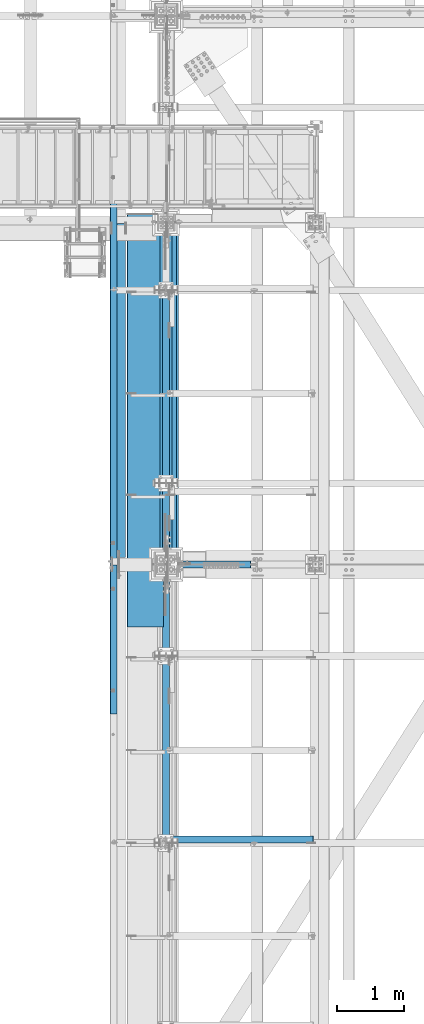
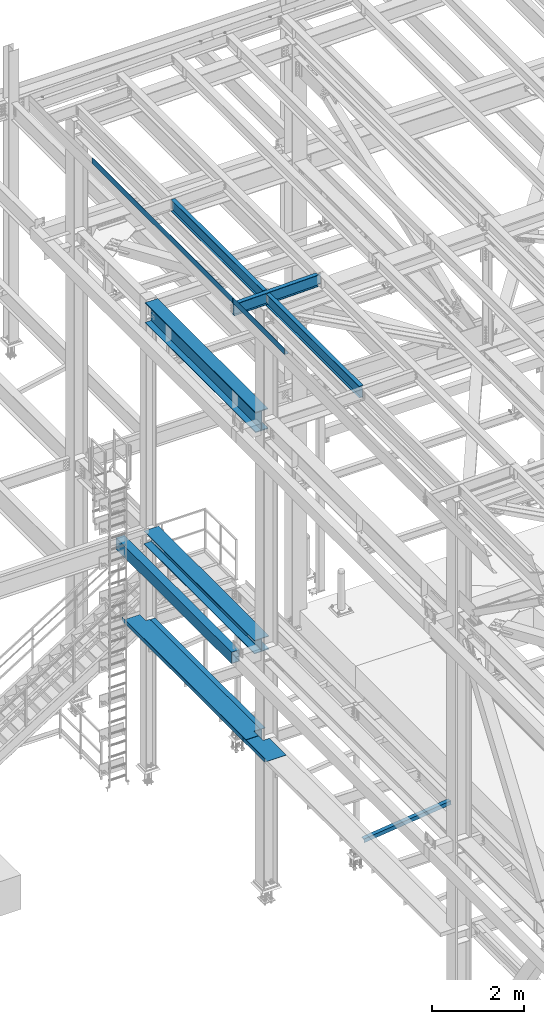
# One storey, part 1877 of 3843: 12 beams, 11 elements without a shape of their own.
"""IFC2X3 building model written with IfcOpenShell, lengths in millimetres."""

from ifc_helpers import new_model, si_unit, frame, origin_with_axes, place, context, subcontext, project, spatial, faceted_brep, material, type_object, element, aggregate, save


model = new_model("IFC2X3")

# Units and contexts
model_context = context("Model", 3, precision=1e-05, world=origin_with_axes())
body_context = subcontext(model_context, "Body", "Model", "MODEL_VIEW")
ifc_project = project(units=[si_unit("LENGTHUNIT", "METRE", prefix="MILLI"), si_unit("AREAUNIT", "SQUARE_METRE"), si_unit("VOLUMEUNIT", "CUBIC_METRE"), si_unit("MASSUNIT", "GRAM", prefix="KILO"), si_unit("TIMEUNIT", "SECOND"), si_unit("PLANEANGLEUNIT", "RADIAN"), si_unit("SOLIDANGLEUNIT", "STERADIAN"), si_unit("THERMODYNAMICTEMPERATUREUNIT", "DEGREE_CELSIUS"), si_unit("LUMINOUSINTENSITYUNIT", "LUMEN")], contexts=[model_context])

# Site, building, storey
site_placement = place(None, origin_with_axes())
site = spatial("IfcSite", under=ifc_project, at=site_placement, CompositionType="ELEMENT")
building_placement = place(site_placement, origin_with_axes())
building = spatial("IfcBuilding", under=site, at=building_placement, Name="Undefined", CompositionType="ELEMENT")
storey_placement = place(building_placement, origin_with_axes())
storey = spatial("IfcBuildingStorey", under=building, at=storey_placement, Name="Undefined", CompositionType="ELEMENT", Elevation=0.0)

# Assembly, beam
assembly_1_placement = place(storey_placement, origin_with_axes())
assembly_1 = element("IfcElementAssembly", 1, at=assembly_1_placement, inside=storey, Name="ANGLE", AssemblyPlace="NOTDEFINED", PredefinedType="RIGID_FRAME")
ifc_material_1 = material(Name="STEEL/A572-50")
beam_type_1 = type_object("IfcBeamType", Name="L4X4X3/8", PredefinedType="NOTDEFINED")
beam_1_placement = place(assembly_1_placement, frame((38788.5093206542, 79860.675782, 33960.1419503901), z_axis=(0.0, 1.0, 0.0), x_axis=(-0.993268693078032, 0.0, -0.115833084009098)))
beam_1 = element("IfcBeam", 2, at=beam_1_placement, type_object=beam_type_1, material=ifc_material_1, Name="ANGLE", ObjectType="L4X4X3/8", context=body_context, shape_type="Brep", body=[
    faceted_brep([(0.0, 50.8000000000029, -50.8000000000029), (0.0, 50.8000000000029, 50.8000000000029), (2192.8104802954, 50.7999999940694, 50.8000000000029), (2192.8104802954, 50.7999999940694, -50.8000000000029), (0.0, 41.2750000000015, 50.8000000000029), (2192.81048029537, 41.2749999940788, 50.8000000000029), (0.0, 41.2749999999942, -41.2750000000015), (2192.81048029537, 41.2749999940788, -41.2750000000015), (0.0, -50.8000000000029, -41.2750000000015), (2192.81048029512, -50.8000000058528, -41.2750000000015), (0.0, -50.8000000000029, -50.8000000000029), (2192.81048029512, -50.8000000058528, -50.8000000000029)], [[[0, 1, 2, 3]], [[1, 4, 5, 2]], [[4, 6, 7, 5]], [[6, 8, 9, 7]], [[8, 10, 11, 9]], [[10, 0, 3, 11]], [[5, 7, 9, 11, 3, 2]], [[10, 8, 6, 4, 1, 0]]]),
])
aggregate(assembly_1, [beam_1])

assembly_2_placement = place(storey_placement, origin_with_axes())
assembly_2 = element("IfcElementAssembly", 3, at=assembly_2_placement, inside=storey, Name="BEAM", AssemblyPlace="NOTDEFINED", PredefinedType="RIGID_FRAME")
ifc_material_2 = material(Name="STEEL/A36")
beam_type_2 = type_object("IfcBeamType", PredefinedType="NOTDEFINED")
beam_2_placement = place(assembly_2_placement, frame((35839.3101110435, 82861.15, 45717.1843160686), z_axis=(0.0, -1.0, 0.0), x_axis=(-0.999776270257024, 0.0, -0.0211520550054595)))
beam_2 = element("IfcBeam", 4, at=beam_2_placement, type_object=beam_type_2, material=ifc_material_2, Name="BENT_PLATE", context=body_context, shape_type="Brep", body=[
    faceted_brep([(95.2499999992069, -161.924999997405, 1117.60000004772), (98.4252606008595, -161.924999997434, 1120.77499999999), (98.4252606000809, -0.000137225979415234, 1120.77499999999), (95.2499999984138, -3.17499999993015, 1117.60000004771), (0.0, -0.000137226030346937, 1120.77499999999), (-7.27595761418343e-12, -3.17500000000291, 1117.60000004771), (-7.27595761418343e-12, -3.17500000000291, -1120.775), (95.2499999984138, -3.17499999993015, -1120.775), (-7.27595761418343e-12, 3.17499999998836, 1120.775), (-7.27595761418343e-12, 3.17499999998836, -1120.775), (101.599999998383, 3.17500000006112, 1120.775), (101.599999998383, 3.17500000006112, -1120.775), (101.599999999198, -161.924999997369, 1120.775), (101.599999999198, -161.924999997369, -1120.775), (95.2499999992069, -161.924999997405, -1120.775)], [[[0, 1, 2, 3]], [[3, 2, 4, 5]], [[6, 7, 3, 5]], [[8, 9, 6, 5, 4]], [[9, 8, 10, 11]], [[11, 10, 12, 13]], [[1, 12, 10, 8, 4, 2]], [[7, 14, 0, 3]], [[7, 6, 9, 11, 13, 14]], [[14, 13, 12, 1, 0]]]),
])
aggregate(assembly_2, [beam_2])

assembly_3_placement = place(storey_placement, origin_with_axes())
assembly_3 = element("IfcElementAssembly", 5, at=assembly_3_placement, inside=storey, Name="BEAM", AssemblyPlace="NOTDEFINED", PredefinedType="RIGID_FRAME")
beam_3_placement = place(assembly_3_placement, frame((35839.3101110586, 87048.975, 45717.1843160679), z_axis=(0.0, -1.0, 0.0), x_axis=(-0.999776270257024, 0.0, -0.0211520550054595)))
beam_3 = element("IfcBeam", 6, at=beam_3_placement, type_object=beam_type_2, material=ifc_material_2, Name="BENT_PLATE", context=body_context, shape_type="Brep", body=[
    faceted_brep([(-3.50355549016967e-07, -3.17499999742722, -3048.00000001723), (3.50421032635495e-07, -3.17500000260043, 3048.00000001724), (3.5035191103816e-07, 3.17499999739084, 3048.00000001724), (-3.50424670614302e-07, 3.17500000256405, -3048.00000001723), (101.599999864371, 3.17499999856227, 3048.00000000522), (101.599998739839, 3.17500000373548, -3048.00000002925), (95.249998765099, -3.17499999632128, -3048.00000002851), (95.2499998896274, -3.17500000149448, 3048.00000000597), (101.600000309205, -161.925000875126, 3047.9999999938), (101.599999608374, -161.925000446165, -3048.00000004067), (95.2500003092064, -161.925000900388, 3047.99999999456), (95.2499996083752, -161.925000471427, -3048.00000003992)], [[[0, 1, 2, 3]], [[3, 2, 4, 5]], [[1, 0, 6, 7]], [[5, 4, 8, 9]], [[4, 2, 1, 7, 10, 8]], [[7, 6, 11, 10]], [[6, 0, 3, 5, 9, 11]], [[10, 11, 9, 8]]]),
])
aggregate(assembly_3, [beam_3])

assembly_4_placement = place(storey_placement, origin_with_axes())
assembly_4 = element("IfcElementAssembly", 7, at=assembly_4_placement, inside=storey, Name="BEAM", AssemblyPlace="NOTDEFINED", PredefinedType="RIGID_FRAME")
ifc_material_3 = material(Name="STEEL/A992")
beam_type_3 = type_object("IfcBeamType", Name="W21X101", PredefinedType="NOTDEFINED")
beam_4_placement = place(assembly_4_placement, frame((36576.0, 83985.1, 42197.3375), z_axis=(0.0, 0.0, 1.0), x_axis=(0.0, 1.0, 0.0)))
beam_4 = element("IfcBeam", 8, at=beam_4_placement, type_object=beam_type_3, material=ifc_material_3, Name="BEAM", ObjectType="W21X101", context=body_context, shape_type="Brep", body=[
    faceted_brep([(198.4375, -155.574999999997, -271.462500000001), (198.4375, 155.574999999997, -271.462500000001), (4989.51250000004, 155.574999999997, -271.462500000001), (4989.51250000004, -155.574999999997, -271.462500000001), (198.4375, -155.574999999997, -250.824999999997), (198.4375, -6.34999999999854, -250.824999999997), (198.4375, -6.34999999999854, 250.824999999997), (198.4375, -155.574999999997, 250.824999999997), (198.4375, -155.574999999997, 271.462500000001), (198.4375, 155.574999999997, 271.462500000001), (198.4375, 155.574999999997, 250.824999999997), (198.4375, 6.34999999999854, 250.824999999997), (198.4375, 6.34999999999854, -250.824999999997), (198.4375, 155.574999999997, -250.824999999997), (4989.51250000004, -155.574999999997, -250.824999999997), (4989.51250000004, -6.34999999999854, -250.824999999997), (4989.51250000004, -6.34999999999854, 250.824999999997), (4989.51250000004, -155.574999999997, 250.824999999997), (4989.51250000004, -155.574999999997, 271.462500000001), (4989.51250000004, 155.574999999997, 271.462500000001), (4989.51250000004, 155.574999999997, 250.824999999997), (4989.51250000004, 6.34999999999854, 250.824999999997), (4989.51250000004, 6.34999999999854, -250.824999999997), (4989.51250000004, 155.574999999997, -250.824999999997)], [[[0, 1, 2, 3]], [[0, 4, 5, 6, 7, 8, 9, 10, 11, 12, 13, 1]], [[5, 4, 14, 15]], [[6, 5, 15, 16]], [[7, 6, 16, 17]], [[8, 7, 17, 18]], [[9, 8, 18, 19]], [[10, 9, 19, 20]], [[11, 10, 20, 21]], [[12, 11, 21, 22]], [[13, 12, 22, 23]], [[1, 13, 23, 2]], [[22, 21, 20, 19, 18, 17, 16, 15, 14, 3, 2, 23]], [[4, 0, 3, 14]]]),
])
aggregate(assembly_4, [beam_4])

assembly_5_placement = place(storey_placement, origin_with_axes())
assembly_5 = element("IfcElementAssembly", 9, at=assembly_5_placement, inside=storey, Name="GIRT", AssemblyPlace="NOTDEFINED", PredefinedType="RIGID_FRAME")
ifc_material_4 = material()
beam_type_4 = type_object("IfcBeamType", Name="HSS12X8X3/8", PredefinedType="NOTDEFINED")
beam_5_placement = place(assembly_5_placement, frame((35861.625, 83985.1, 36252.15), z_axis=(0.0, 0.0, 1.0), x_axis=(0.0, 1.0, 0.0)))
beam_5 = element("IfcBeam", 10, at=beam_5_placement, type_object=beam_type_4, material=ifc_material_4, Name="GIRT", ObjectType="HSS12X8X3/8", context=body_context, shape_type="Brep", body=[
    faceted_brep([(5113.33750000001, -101.599999999999, 152.400000000001), (5113.33750000001, 101.599999999999, 152.400000000001), (103.1875, 101.600000000006, 152.400000000001), (103.1875, -101.600000000006, 152.400000000001), (5113.33750000001, -101.599999999999, -152.400000000001), (103.1875, -101.600000000006, -152.400000000001), (5113.33750000001, 101.599999999999, -152.400000000001), (103.1875, 101.600000000006, -152.400000000001), (5113.33750000001, -92.0749999999971, 142.875), (5113.33750000001, 92.0749999999971, 142.875), (5113.33750000001, 92.0749999999971, -142.875), (5113.33750000001, -92.0749999999971, -142.875), (103.1875, -92.0749999999971, 142.875), (103.1875, 92.0749999999971, 142.875), (103.1875, 92.0749999999971, -142.875), (103.1875, -92.0749999999971, -142.875)], [[[0, 1, 2, 3]], [[4, 0, 3, 5]], [[6, 4, 5, 7]], [[1, 6, 7, 2]], [[0, 4, 6, 1], [8, 9, 10, 11]], [[9, 8, 12, 13]], [[10, 9, 13, 14]], [[11, 10, 14, 15]], [[8, 11, 15, 12]], [[7, 5, 3, 2], [14, 13, 12, 15]]]),
])
aggregate(assembly_5, [beam_5])

assembly_6_placement = place(storey_placement, origin_with_axes())
assembly_6 = element("IfcElementAssembly", 11, at=assembly_6_placement, inside=storey, Name="BEAM", AssemblyPlace="NOTDEFINED", PredefinedType="RIGID_FRAME")
beam_type_5 = type_object("IfcBeamType", Name="W12X19", PredefinedType="NOTDEFINED")
beam_6_placement = place(assembly_6_placement, frame((36575.9999999997, 83985.1, 45575.6071293694), z_axis=(0.0, 0.0, 1.0), x_axis=(0.0, 1.0, 0.0)))
beam_6 = element("IfcBeam", 12, at=beam_6_placement, type_object=beam_type_5, material=ifc_material_3, Name="BEAM", ObjectType="W12X19", context=body_context, shape_type="Brep", body=[
    faceted_brep([(15.8750000000146, -3.17500000000291, -128.587499998961), (15.8750000000146, 3.17500000000291, -128.587499998961), (53.9750001907523, 3.17500000000291, -128.587499998961), (53.9750001907523, -3.17500000000291, -128.587499998961), (58.8350797087915, 3.17500000000291, -129.554229921552), (58.8350797087915, -3.17500000000291, -129.554229921552), (62.9552561769524, 3.17500000000291, -132.307243822026), (62.9552561769524, -3.17500000000291, -132.307243822026), (65.7082700774336, 3.17500000000291, -136.42742029018), (65.7082700774336, -3.17500000000291, -136.42742029018), (66.6750000000175, -3.17500000000291, -141.287499808226), (66.6750000000175, 3.17500000000291, -141.287499808226), (66.6750000000175, 3.17500000000291, -144.462500000001), (66.6750000000175, 50.8000000000029, -144.462500000001), (66.6750000000175, 50.8000000000029, -153.987500000003), (66.6750000000175, -50.8000000000029, -153.987500000003), (66.6750000000175, -50.8000000000029, -144.462500000001), (66.6750000000175, -3.17500000000291, -144.462500000001), (4048.125, 50.8000000000029, 144.462500000001), (4048.125, 3.17500000000291, 144.462500000001), (66.6750000000175, 3.17500000000291, 144.462500000001), (66.6750000000175, 50.8000000000029, 144.462500000001), (53.9750001907523, -3.17500000000291, 128.587500001042), (53.9750001907523, 3.17500000000291, 128.587500001042), (15.8750000000146, 3.17500000000291, 128.587500001042), (15.8750000000146, -3.17500000000291, 128.587500001042), (58.8350797087915, -3.17500000000291, 129.554229923633), (58.8350797087915, 3.17500000000291, 129.554229923633), (62.9552561769524, -3.17500000000291, 132.307243824107), (62.9552561769524, 3.17500000000291, 132.307243824107), (65.7082700774336, -3.17500000000291, 136.427420292261), (65.7082700774336, 3.17500000000291, 136.427420292261), (66.6750000000175, -3.17500000000291, 141.287499810307), (66.6750000000175, 3.17500000000291, 141.287499810307), (4048.125, -50.8000000000029, 153.987500000003), (4048.125, 50.8000000000029, 153.987500000003), (66.6750000000175, 50.8000000000029, 153.987500000003), (66.6750000000175, -50.8000000000029, 153.987500000003), (4048.125, -50.8000000000029, 144.462500000001), (66.6750000000175, -50.8000000000029, 144.462500000001), (4048.125, -3.17500000000291, 144.462500000001), (66.6750000000175, -3.17500000000291, 144.462500000001), (4048.125, -3.17500000000291, 141.2874998103), (4048.125, 3.17500000000291, 141.2874998103), (4049.09172992258, -3.17500000000291, 136.427420292253), (4049.09172992258, 3.17500000000291, 136.427420292253), (4051.84474382307, -3.17500000000291, 132.3072438241), (4051.84474382307, 3.17500000000291, 132.3072438241), (4055.96492029123, -3.17500000000291, 129.554229923626), (4055.96492029123, 3.17500000000291, 129.554229923626), (4060.82499980927, -3.17500000000291, 128.587500001035), (4060.82499980927, 3.17500000000291, 128.587500001035), (4098.925, -3.17500000000291, 128.587500001035), (4098.925, 3.17500000000291, 128.587500001035), (4098.925, 3.17500000000291, -114.712499998452), (4098.925, 3.17500000000291, 115.887500001547), (4098.925, -3.17500000000291, -128.587499998968), (4098.925, 3.17500000000291, -128.587499998968), (4060.82499980927, -3.17500000000291, -128.587499998968), (4060.82499980927, 3.17500000000291, -128.587499998968), (4055.96492029123, -3.17500000000291, -129.554229921559), (4055.96492029123, 3.17500000000291, -129.554229921559), (4051.84474382307, -3.17500000000291, -132.307243822033), (4051.84474382307, 3.17500000000291, -132.307243822033), (4049.09172992258, -3.17500000000291, -136.427420290187), (4049.09172992258, 3.17500000000291, -136.427420290187), (4048.125, -3.17500000000291, -141.287499808233), (4048.125, 3.17500000000291, -141.287499808233), (4048.125, -3.17500000000291, -144.462500000001), (4048.125, -50.8000000000029, -144.462500000001), (4048.125, -50.8000000000029, -153.987500000003), (4048.125, 50.8000000000029, -153.987500000003), (4048.125, 50.8000000000029, -144.462500000001), (4048.125, 3.17500000000291, -144.462500000001), (15.8750000000146, 3.17500000000291, -114.712499998386), (15.8750000000146, 3.17500000000291, 115.887500001612)], [[[0, 1, 2, 3]], [[3, 2, 4, 5]], [[5, 4, 6, 7]], [[7, 6, 8, 9]], [[10, 11, 12, 13, 14, 15, 16, 17]], [[9, 8, 11, 10]], [[18, 19, 20, 21]], [[22, 23, 24, 25]], [[26, 27, 23, 22]], [[28, 29, 27, 26]], [[30, 31, 29, 28]], [[32, 33, 31, 30]], [[34, 35, 36, 37]], [[38, 34, 37, 39]], [[40, 38, 39, 41]], [[37, 36, 21, 20, 33, 32, 41, 39]], [[35, 18, 21, 36]], [[34, 38, 40, 42, 43, 19, 18, 35]], [[44, 45, 43, 42]], [[46, 47, 45, 44]], [[48, 49, 47, 46]], [[50, 51, 49, 48]], [[52, 53, 51, 50]], [[54, 55, 53, 52, 56, 57]], [[56, 58, 59, 57]], [[60, 61, 59, 58]], [[62, 63, 61, 60]], [[64, 65, 63, 62]], [[66, 67, 65, 64]], [[68, 69, 70, 71, 72, 73, 67, 66]], [[69, 68, 17, 16]], [[70, 69, 16, 15]], [[71, 70, 15, 14]], [[72, 71, 14, 13]], [[73, 72, 13, 12]], [[6, 4, 2, 1, 74, 75, 24, 23, 27, 29, 31, 33, 20, 19, 43, 45, 47, 49, 51, 53, 55, 54, 57, 59, 61, 63, 65, 67, 73, 12, 11, 8]], [[25, 24, 75, 74, 1, 0]], [[68, 66, 64, 62, 60, 58, 56, 52, 50, 48, 46, 44, 42, 40, 41, 32, 30, 28, 26, 22, 25, 0, 3, 5, 7, 9, 10, 17]]]),
])
aggregate(assembly_6, [beam_6])

assembly_7_placement = place(storey_placement, origin_with_axes())
assembly_7 = element("IfcElementAssembly", 13, at=assembly_7_placement, inside=storey, Name="BEAM", AssemblyPlace="NOTDEFINED", PredefinedType="RIGID_FRAME")
beam_7_placement = place(assembly_7_placement, frame((36575.9999999941, 79806.7999999999, 45575.6071293694), z_axis=(0.0, 0.0, 1.0), x_axis=(0.0, 1.0, 0.0)))
beam_7 = element("IfcBeam", 14, at=beam_7_placement, type_object=beam_type_5, material=ifc_material_3, Name="BEAM", ObjectType="W12X19", context=body_context, shape_type="Brep", body=[
    faceted_brep([(4111.62499999991, -3.17500000000291, -144.462500000001), (4111.62499999991, -50.8000000000029, -144.462500000001), (4111.62499999991, -50.8000000000029, -153.987500000003), (4111.62499999991, 50.8000000000029, -153.987500000003), (4111.62499999991, 50.8000000000029, -144.462500000001), (4111.62499999991, 3.17500000000291, -144.462500000001), (4111.62499999991, 3.17500000000291, -141.287499808204), (4111.62499999991, -3.17500000000291, -141.287499808204), (4112.5917299225, 3.17500000000291, -136.427420290158), (4112.5917299225, -3.17500000000291, -136.427420290158), (4115.34474382298, 3.17500000000291, -132.307243822004), (4115.34474382298, -3.17500000000291, -132.307243822004), (4119.46492029114, 3.17500000000291, -129.55422992153), (4119.46492029114, -3.17500000000291, -129.55422992153), (4124.32499980918, 3.17500000000291, -128.587499998939), (4124.32499980918, -3.17500000000291, -128.587499998939), (4162.42499999992, -3.17500000000291, -128.587499998939), (4162.42499999992, 3.17500000000291, -128.587499998939), (4111.62499999991, 50.8000000000029, 144.462500000001), (4111.62499999991, 3.17500000000291, 144.462500000001), (66.6750000000175, 3.17500000000291, 144.462500000001), (66.6750000000175, 50.8000000000029, 144.462500000001), (66.6750000000175, -3.17500000000291, -141.287499808226), (66.6750000000175, 3.17500000000291, -141.287499808226), (66.6750000000175, 3.17500000000291, -144.462500000001), (66.6750000000175, 50.8000000000029, -144.462500000001), (66.6750000000175, 50.8000000000029, -153.987500000003), (66.6750000000175, -50.8000000000029, -153.987500000003), (66.6750000000175, -50.8000000000029, -144.462500000001), (66.6750000000175, -3.17500000000291, -144.462500000001), (65.7082700774336, -3.17500000000291, -136.42742029018), (65.7082700774336, 3.17500000000291, -136.42742029018), (62.9552561769524, -3.17500000000291, -132.307243822026), (62.9552561769524, 3.17500000000291, -132.307243822026), (58.8350797087915, -3.17500000000291, -129.554229921552), (58.8350797087915, 3.17500000000291, -129.554229921552), (53.9750001907523, -3.17500000000291, -128.587499998961), (53.9750001907523, 3.17500000000291, -128.587499998961), (15.8750000000146, -3.17500000000291, -128.587499998961), (15.8750000000146, 3.17500000000291, -128.587499998961), (15.8750000000146, -3.17500000000291, 128.587500001042), (15.8750000000146, 3.17500000000291, 128.587500001042), (15.8750000000146, 3.17500000000291, 115.887500001612), (15.8750000000146, 3.17500000000291, -114.712499998386), (53.9750001907523, -3.17500000000291, 128.587500001042), (53.9750001907523, 3.17500000000291, 128.587500001042), (58.8350797087915, -3.17500000000291, 129.554229923633), (58.8350797087915, 3.17500000000291, 129.554229923633), (62.9552561769524, -3.17500000000291, 132.307243824107), (62.9552561769524, 3.17500000000291, 132.307243824107), (65.7082700774336, -3.17500000000291, 136.427420292261), (65.7082700774336, 3.17500000000291, 136.427420292261), (66.6750000000175, -3.17500000000291, 141.287499810307), (66.6750000000175, 3.17500000000291, 141.287499810307), (66.6750000000175, -50.8000000000029, 153.987500000003), (66.6750000000175, 50.8000000000029, 153.987500000003), (66.6750000000175, -3.17500000000291, 144.462500000001), (66.6750000000175, -50.8000000000029, 144.462500000001), (4111.62499999991, -3.17500000000291, 144.462500000001), (4111.62499999991, -50.8000000000029, 144.462500000001), (4111.62499999991, -50.8000000000029, 153.987500000003), (4111.62499999991, 50.8000000000029, 153.987500000003), (4111.62499999991, -3.17500000000291, 141.287499810329), (4111.62499999991, 3.17500000000291, 141.287499810329), (4112.5917299225, -3.17500000000291, 136.427420292282), (4112.5917299225, 3.17500000000291, 136.427420292282), (4115.34474382298, -3.17500000000291, 132.307243824129), (4115.34474382298, 3.17500000000291, 132.307243824129), (4119.46492029114, -3.17500000000291, 129.554229923655), (4119.46492029114, 3.17500000000291, 129.554229923655), (4124.32499980918, -3.17500000000291, 128.587500001064), (4124.32499980918, 3.17500000000291, 128.587500001064), (4162.42499999992, -3.17500000000291, 128.587500001064), (4162.42499999992, 3.17500000000291, 128.587500001064), (4162.42499999992, 3.17500000000291, -114.712499998423), (4162.42499999992, 3.17500000000291, 115.887500001576)], [[[0, 1, 2, 3, 4, 5, 6, 7]], [[7, 6, 8, 9]], [[9, 8, 10, 11]], [[11, 10, 12, 13]], [[13, 12, 14, 15]], [[16, 15, 14, 17]], [[18, 19, 20, 21]], [[22, 23, 24, 25, 26, 27, 28, 29]], [[30, 31, 23, 22]], [[32, 33, 31, 30]], [[34, 35, 33, 32]], [[36, 37, 35, 34]], [[38, 39, 37, 36]], [[40, 41, 42, 43, 39, 38]], [[44, 45, 41, 40]], [[46, 47, 45, 44]], [[48, 49, 47, 46]], [[50, 51, 49, 48]], [[52, 53, 51, 50]], [[54, 55, 21, 20, 53, 52, 56, 57]], [[58, 59, 57, 56]], [[59, 60, 54, 57]], [[60, 61, 55, 54]], [[61, 18, 21, 55]], [[60, 59, 58, 62, 63, 19, 18, 61]], [[64, 65, 63, 62]], [[66, 67, 65, 64]], [[68, 69, 67, 66]], [[70, 71, 69, 68]], [[72, 73, 71, 70]], [[74, 75, 73, 72, 16, 17]], [[33, 35, 37, 39, 43, 42, 41, 45, 47, 49, 51, 53, 20, 19, 63, 65, 67, 69, 71, 73, 75, 74, 17, 14, 12, 10, 8, 6, 5, 24, 23, 31]], [[5, 4, 25, 24]], [[4, 3, 26, 25]], [[3, 2, 27, 26]], [[2, 1, 28, 27]], [[1, 0, 29, 28]], [[0, 7, 9, 11, 13, 15, 16, 72, 70, 68, 66, 64, 62, 58, 56, 52, 50, 48, 46, 44, 40, 38, 36, 34, 32, 30, 22, 29]]]),
])
aggregate(assembly_7, [beam_7])

assembly_8_placement = place(storey_placement, origin_with_axes())
assembly_8 = element("IfcElementAssembly", 15, at=assembly_8_placement, inside=storey, Name="BEAM", AssemblyPlace="NOTDEFINED", PredefinedType="RIGID_FRAME")
beam_8_placement = place(assembly_8_placement, frame((35741.0571586919, 83985.1, 45557.9079249894), z_axis=(-0.0211520980073474, 0.0, 0.999776269347241), x_axis=(0.999776270257024, 0.0, 0.0211520550054619)))
beam_8 = element("IfcBeam", 16, at=beam_8_placement, type_object=beam_type_5, material=ifc_material_3, Name="BEAM", ObjectType="W12X19", context=body_context, shape_type="Brep", body=[
    faceted_brep([(2105.30056050701, -3.17500000000291, -144.462499997637), (2105.30056050701, -50.8000000000029, -144.462499997637), (2105.30056050701, -50.8000000000029, -153.987499997624), (2105.30056050701, 50.8000000000029, -153.987499997624), (2105.30056050701, 50.8000000000029, -144.462499997637), (2105.30056050701, 3.17500000000291, -144.462499997637), (2105.300560507, 3.17500000000291, -140.62588802036), (2105.300560507, -3.17500000000291, -140.62588802036), (2106.26729042958, 3.17500000000291, -135.765808502336), (2106.26729042958, -3.17500000000291, -135.765808502336), (2109.02030433004, 3.17500000000291, -131.645632034189), (2109.02030433004, -3.17500000000291, -131.645632034189), (2113.14048079817, 3.17500000000291, -128.89261813373), (2113.14048079817, -3.17500000000291, -128.89261813373), (2118.00056031619, 3.17500000000291, -127.925888211139), (2118.00056031619, -3.17500000000291, -127.925888211139), (2187.8505604885, -3.17500000000291, -127.925888211081), (2187.8505604885, 3.17500000000291, -127.925888211081), (4.36557456851006e-11, 3.17500000000291, 144.462499999994), (4.36557456851006e-11, 50.8000000000029, 144.462499999994), (2105.30057124554, 50.8000000000029, 144.462499999463), (2105.30057124554, 3.17500000000291, 144.462499999463), (-3.63797880709171e-11, -50.8000000000029, -153.987499999988), (-3.63797880709171e-11, -50.8000000000029, -144.46249999998), (-3.63797880709171e-11, -3.17500000000291, -144.46249999998), (4.36557456851006e-11, -3.17500000000291, 144.462499999994), (4.36557456851006e-11, -50.8000000000029, 144.462499999994), (3.63797880709171e-11, -50.8000000000029, 153.987499999988), (3.63797880709171e-11, 50.8000000000029, 153.987499999988), (-3.63797880709171e-11, 3.17500000000291, -144.46249999998), (-3.63797880709171e-11, 50.8000000000029, -144.46249999998), (-3.63797880709171e-11, 50.8000000000029, -153.987499999988), (2105.30057124554, -3.17500000000291, 144.462499999463), (2105.30057124554, -50.8000000000029, 144.462499999463), (2105.3005622995, -50.8000000000029, 153.987499999464), (2105.3005622995, 50.8000000000029, 153.987499999464), (2105.30056050601, -3.17500000000291, 141.949111594062), (2105.30056050601, 3.17500000000291, 141.949111594062), (2106.2672904286, -3.17500000000291, 137.089032076052), (2106.2672904286, 3.17500000000291, 137.089032076052), (2109.02030432906, -3.17500000000291, 132.96885560792), (2109.02030432906, 3.17500000000291, 132.96885560792), (2113.1404807972, -3.17500000000291, 130.215841707461), (2113.1404807972, 3.17500000000291, 130.215841707461), (2118.00056031522, -3.17500000000291, 129.249111784884), (2118.00056031522, 3.17500000000291, 129.249111784884), (2187.85056048849, -3.17500000000291, 129.249111784935), (2187.85056048849, 3.17500000000291, 129.249111784935)], [[[0, 1, 2, 3, 4, 5, 6, 7]], [[7, 6, 8, 9]], [[9, 8, 10, 11]], [[11, 10, 12, 13]], [[13, 12, 14, 15]], [[16, 15, 14, 17]], [[18, 19, 20, 21]], [[22, 23, 24, 25, 26, 27, 28, 19, 18, 29, 30, 31]], [[26, 25, 32, 33]], [[27, 26, 33, 34]], [[28, 27, 34, 35]], [[19, 28, 35, 20]], [[34, 33, 32, 36, 37, 21, 20, 35]], [[38, 39, 37, 36]], [[40, 41, 39, 38]], [[42, 43, 41, 40]], [[44, 45, 43, 42]], [[46, 47, 45, 44]], [[47, 46, 16, 17]], [[12, 10, 8, 6, 5, 29, 18, 21, 37, 39, 41, 43, 45, 47, 17, 14]], [[30, 29, 5, 4]], [[31, 30, 4, 3]], [[22, 31, 3, 2]], [[23, 22, 2, 1]], [[24, 23, 1, 0]], [[46, 44, 42, 40, 38, 36, 32, 25, 24, 0, 7, 9, 11, 13, 15, 16]]]),
])
aggregate(assembly_8, [beam_8])

assembly_9_placement = place(storey_placement, origin_with_axes())
assembly_9 = element("IfcElementAssembly", 17, at=assembly_9_placement, inside=storey, Name="BEAM", AssemblyPlace="NOTDEFINED", PredefinedType="RIGID_FRAME")
beam_type_6 = type_object("IfcBeamType", PredefinedType="NOTDEFINED")
beam_9_placement = place(assembly_9_placement, frame((36537.9000000001, 86615.5875, 34039.175), z_axis=(0.0, -1.0, 0.0), x_axis=(-1.0, 0.0, 0.0)))
beam_9 = element("IfcBeam", 18, at=beam_9_placement, type_object=beam_type_6, material=ifc_material_2, Name="BENT_PLATE", context=body_context, shape_type="Brep", body=[
    faceted_brep([(158.750000000138, -3.17500000000291, 2432.05000000003), (158.750000000138, 3.17500000000291, 2432.05000000003), (0.0, 3.17500000000291, 2432.05000000002), (0.0, -3.17500000000291, 2432.05000000002), (158.750000000138, -3.17500000000291, 2627.31300000004), (158.750000000138, 3.17500000000291, 2627.31299999999), (0.0, -3.17500000000291, -2359.02500000001), (0.0, 3.17500000000291, -2359.02500000001), (98.4250000001412, 3.17500000000291, -2359.02500000001), (98.4250000001412, -3.17500000000291, -2359.02500000001), (98.4250000001412, 3.17500000000291, -2627.31299999999), (98.4250000001412, -3.17500000000291, -2627.31299999999), (546.099973958473, 3.17500000000291, -2627.31299999999), (546.100000000144, -98.4249983722475, -2627.31299999999), (539.750000000138, -98.4249999998501, -2627.31299999999), (539.749975586077, -3.17500000000291, -2627.31299999999), (546.099973958473, 3.17500000000291, 2627.31299999999), (546.100000000144, -98.4249983722475, 2627.31299999999), (539.750000000138, -98.4249999998501, 2627.31299999999), (539.749975586077, -3.17500000000291, 2627.31299999999)], [[[0, 1, 2, 3]], [[4, 5, 1, 0]], [[6, 7, 8, 9]], [[9, 8, 10, 11]], [[12, 13, 14, 15, 11, 10]], [[12, 16, 17, 13]], [[18, 14, 13, 17]], [[19, 15, 14, 18]], [[3, 6, 9, 11, 15, 19, 4, 0]], [[7, 6, 3, 2]], [[16, 12, 10, 8, 7, 2, 1, 5]], [[19, 18, 17, 16, 5, 4]]]),
])

assembly_10_placement = place(storey_placement, origin_with_axes())
assembly_10 = element("IfcElementAssembly", 19, at=assembly_10_placement, inside=storey, Name="BEAM", AssemblyPlace="NOTDEFINED", PredefinedType="RIGID_FRAME")
beam_10_placement = place(assembly_10_placement, frame((36537.9, 83515.2, 34039.175), z_axis=(0.0, -1.0, 0.0), x_axis=(-1.0, 0.0, 0.0)))
beam_10 = element("IfcBeam", 20, at=beam_10_placement, type_object=beam_type_6, material=ifc_material_2, Name="BENT_PLATE", context=body_context, shape_type="Brep", body=[
    faceted_brep([(539.750000000022, -3.17500000000291, 463.550000047704), (542.924977064133, -4.76939021609724e-08, 466.725000000006), (0.0, -4.76939021609724e-08, 466.725000000006), (0.0, -3.17500000000291, 463.55000004769), (539.750000000022, -98.4249999999738, 463.550000047704), (542.924977064133, -98.4249999999738, 466.725000000006), (0.0, -3.17500000000291, -271.462500000009), (158.750000000022, -3.17500000000291, -271.462500000009), (158.750000000022, -3.17500000000291, -466.725000000006), (539.750000000022, -3.17500000000291, -466.725000000006), (158.750000000022, 3.17500000000291, -271.462500000009), (158.750000000022, 3.17500000000291, -466.725000000006), (0.0, 3.17500000000291, -271.462500000009), (546.100000000028, -98.4249999999738, 466.725000000006), (546.100000000028, 3.17500000000291, 466.725000000006), (0.0, 3.17500000000291, 466.725000000006), (546.100000000028, 3.17500000000291, -466.725000000006), (546.100000000028, -98.4249999999738, -466.725000000006), (539.750000000022, -98.4249999999738, -466.725000000006)], [[[0, 1, 2, 3]], [[4, 5, 1, 0]], [[6, 7, 8, 9, 0, 3]], [[7, 10, 11, 8]], [[6, 12, 10, 7]], [[5, 13, 14, 15, 2, 1]], [[16, 14, 13, 17]], [[18, 17, 13, 5, 4]], [[9, 18, 4, 0]], [[16, 17, 18, 9, 8, 11]], [[15, 14, 16, 11, 10, 12]], [[15, 12, 6, 3, 2]]]),
])
aggregate(assembly_10, [beam_10])

# Beam
beam_type_7 = type_object("IfcBeamType", Name="W16X40", PredefinedType="NOTDEFINED")
beam_11_placement = place(assembly_9_placement, frame((36576.0, 83985.1, 33832.8), z_axis=(0.0, 0.0, 1.0), x_axis=(0.0, 1.0, 0.0)))
beam_11 = element("IfcBeam", 21, at=beam_11_placement, type_object=beam_type_7, material=ifc_material_3, Name="BEAM", ObjectType="W16X40", context=body_context, shape_type="Brep", body=[
    faceted_brep([(198.4375, -88.9000000000015, -203.199999999997), (198.4375, 88.9000000000015, -203.199999999997), (4989.51250000003, 88.9000000000015, -203.199999999997), (4989.51250000003, -88.9000000000015, -203.199999999997), (198.4375, -88.9000000000015, -190.5), (198.4375, -3.96875, -190.5), (198.4375, -3.96875, -140.440014546963), (198.4375, -3.96875, 165.839999999997), (198.4375, -3.96875, 190.5), (198.4375, -88.9000000000015, 190.5), (198.4375, -88.9000000000015, 203.199999999997), (198.4375, 88.9000000000015, 203.199999999997), (198.4375, 88.9000000000015, 190.5), (198.4375, 3.96875, 190.5), (198.4375, 3.96875, -190.5), (198.4375, 88.9000000000015, -190.5), (4989.51250000003, -88.9000000000015, -190.5), (4989.51250000003, -3.96875, -190.5), (4989.51250000003, -3.96875, -140.439985200275), (4989.51250000003, -3.96875, 165.839999999997), (4989.51250000003, -3.96875, 190.5), (4989.51250000003, -88.9000000000015, 190.5), (4989.51250000003, -88.9000000000015, 203.199999999997), (4989.51250000003, 88.9000000000015, 203.199999999997), (4989.51250000003, 88.9000000000015, 190.5), (4989.51250000003, 3.96875, 190.5), (4989.51250000003, 3.96875, -190.5), (4989.51250000003, 88.9000000000015, -190.5)], [[[0, 1, 2, 3]], [[0, 4, 5, 6, 7, 8, 9, 10, 11, 12, 13, 14, 15, 1]], [[5, 4, 16, 17]], [[8, 7, 6, 5, 17, 18, 19, 20]], [[9, 8, 20, 21]], [[10, 9, 21, 22]], [[11, 10, 22, 23]], [[12, 11, 23, 24]], [[13, 12, 24, 25]], [[14, 13, 25, 26]], [[15, 14, 26, 27]], [[1, 15, 27, 2]], [[26, 25, 24, 23, 22, 21, 20, 19, 18, 17, 16, 3, 2, 27]], [[4, 0, 3, 16]]]),
])

aggregate(assembly_9, [beam_9, beam_11])

# Assembly, beam
assembly_11_placement = place(storey_placement, origin_with_axes())
assembly_11 = element("IfcElementAssembly", 22, at=assembly_11_placement, inside=storey, Name="BEAM", AssemblyPlace="NOTDEFINED", PredefinedType="RIGID_FRAME")
beam_type_8 = type_object("IfcBeamType", Name="W14X90", PredefinedType="NOTDEFINED")
beam_12_placement = place(assembly_11_placement, frame((36576.0, 83985.1, 36258.5), z_axis=(0.0, 0.0, 1.0), x_axis=(0.0, 1.0, 0.0)))
beam_12 = element("IfcBeam", 23, at=beam_12_placement, type_object=beam_type_8, material=ifc_material_3, Name="BEAM", ObjectType="W14X90", context=body_context, shape_type="Brep", body=[
    faceted_brep([(198.4375, 184.150000000001, -177.800000000003), (198.4375, 184.150000000001, -160.337500000001), (4989.51250000003, 184.150000000001, -160.337500000001), (4989.51250000003, 184.150000000001, -177.800000000003), (198.4375, 5.55625000000146, -160.337500000001), (4989.51250000003, 5.55625000000146, -160.337500000001), (198.4375, 5.55625000000146, 160.337500000001), (4989.51250000003, 5.55625000000146, 160.337500000001), (198.4375, 184.150000000001, 160.337500000001), (4989.51250000003, 184.150000000001, 160.337500000001), (198.4375, 184.150000000001, 177.800000000003), (4989.51250000003, 184.150000000001, 177.800000000003), (198.4375, -184.150000000001, 177.800000000003), (4989.51250000003, -184.150000000001, 177.800000000003), (198.4375, -184.150000000001, 160.337500000001), (4989.51250000003, -184.150000000001, 160.337500000001), (198.4375, -5.55625000000146, 160.337500000001), (4989.51250000003, -5.55625000000146, 160.337500000001), (198.4375, -5.55625000000146, -160.337500000001), (4989.51250000003, -5.55625000000146, -160.337500000001), (198.4375, -184.150000000001, -160.337500000001), (4989.51250000003, -184.150000000001, -160.337500000001), (198.4375, -184.150000000001, -177.800000000003), (4989.51250000003, -184.150000000001, -177.800000000003)], [[[0, 1, 2, 3]], [[1, 4, 5, 2]], [[4, 6, 7, 5]], [[6, 8, 9, 7]], [[8, 10, 11, 9]], [[10, 12, 13, 11]], [[12, 14, 15, 13]], [[14, 16, 17, 15]], [[16, 18, 19, 17]], [[18, 20, 21, 19]], [[20, 22, 23, 21]], [[22, 0, 3, 23]], [[5, 7, 9, 11, 13, 15, 17, 19, 21, 23, 3, 2]], [[22, 20, 18, 16, 14, 12, 10, 8, 6, 4, 1, 0]]]),
])
aggregate(assembly_11, [beam_12])

save(model, "model.ifc")
